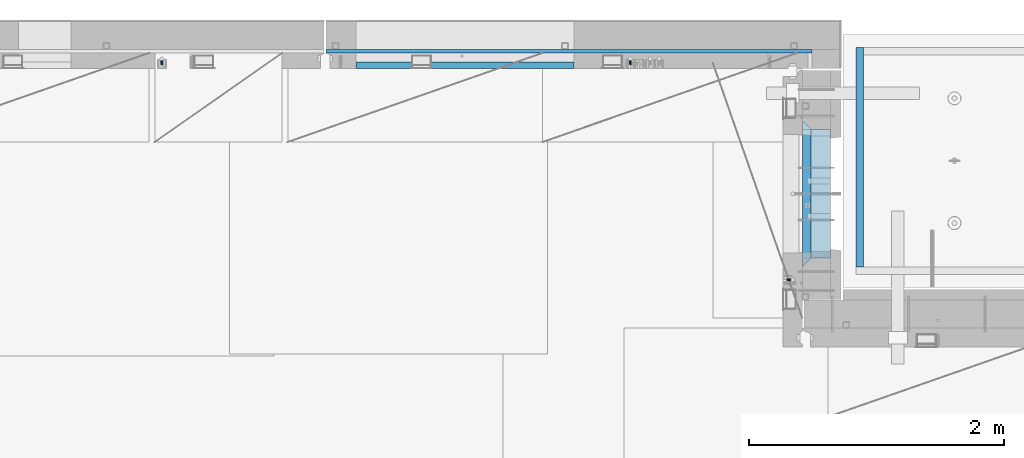
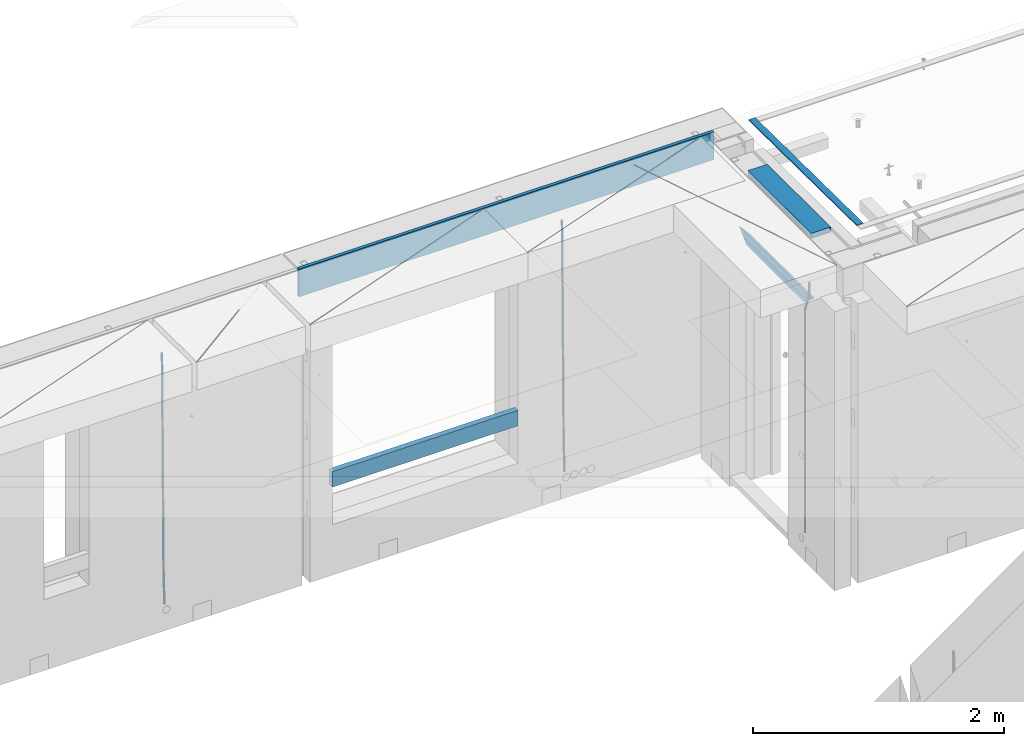
# One storey, part 126 of 352: 9 beams, 4 elements without a shape of their own.
"""IFC2X3 building model written with IfcOpenShell, lengths in millimetres."""

from ifc_helpers import new_model, si_unit, frame, origin_with_axes, place, context, subcontext, project, spatial, faceted_brep, material, type_object, element, aggregate, save


model = new_model("IFC2X3")

# Units and contexts
model_context = context("Model", 3, precision=1e-05, world=origin_with_axes())
body_context = subcontext(model_context, "Body", "Model", "MODEL_VIEW")
ifc_project = project(units=[si_unit("LENGTHUNIT", "METRE", prefix="MILLI"), si_unit("AREAUNIT", "SQUARE_METRE"), si_unit("VOLUMEUNIT", "CUBIC_METRE"), si_unit("MASSUNIT", "GRAM", prefix="KILO"), si_unit("TIMEUNIT", "SECOND"), si_unit("PLANEANGLEUNIT", "RADIAN"), si_unit("SOLIDANGLEUNIT", "STERADIAN"), si_unit("THERMODYNAMICTEMPERATUREUNIT", "DEGREE_CELSIUS"), si_unit("LUMINOUSINTENSITYUNIT", "LUMEN")], contexts=[model_context])

# Site, building, storey
site_placement = place(None, origin_with_axes())
site = spatial("IfcSite", under=ifc_project, at=site_placement, CompositionType="ELEMENT")
building_placement = place(site_placement, origin_with_axes())
building = spatial("IfcBuilding", under=site, at=building_placement, CompositionType="ELEMENT")
storey_placement = place(building_placement, origin_with_axes())
storey = spatial("IfcBuildingStorey", under=building, at=storey_placement, Name="6", CompositionType="ELEMENT", Elevation=0.0)

# Assembly, beams
assembly_1_placement = place(storey_placement, origin_with_axes())
assembly_1 = element("IfcElementAssembly", 1, at=assembly_1_placement, inside=storey, AssemblyPlace="NOTDEFINED", PredefinedType="REINFORCEMENT_UNIT")
ifc_material_1 = material(Name="CONCRETE/C25/30")
beam_type_1 = type_object("IfcBeamType", PredefinedType="NOTDEFINED")
beam_1_placement = place(assembly_1_placement, frame((31494.9951872276, 21060.0002716511, 99140.0), z_axis=(0.0, 0.0, -1.0), x_axis=(0.0, 1.0, 0.0)))
beam_1 = element("IfcBeam", 2, at=beam_1_placement, type_object=beam_type_1, material=ifc_material_1, Name="SK", context=body_context, shape_type="Brep", body=[
    faceted_brep([(70.0000000000164, -35.0, 35.0), (70.0000000000164, 35.0, 35.0), (0.0, -35.0, -35.0), (1079.99961853027, 35.0, 35.0), (1149.99961853027, -35.0, -35.0), (1079.99961853027, -35.0, 35.0)], [[[0, 1, 2]], [[2, 1, 3, 4]], [[0, 2, 4, 5]], [[1, 0, 5, 3]], [[4, 3, 5]]]),
])
beam_type_2 = type_object("IfcBeamType", PredefinedType="NOTDEFINED")
beam_2_placement = place(assembly_1_placement, frame((31494.9951872276, 21130.0002716511, 99080.0), z_axis=(0.0, 0.0, -1.0), x_axis=(0.0, 1.0, 0.0)))
beam_2 = element("IfcBeam", 3, at=beam_2_placement, type_object=beam_type_2, material=ifc_material_1, Name="SK", context=body_context, shape_type="Brep", body=[
    faceted_brep([(0.0, -35.0, -25.0), (43.8457723764295, -35.0, 18.8461538461561), (45.6406441713007, 35.0, 20.6410256410309), (0.0, 35.0, -25.0), (1009.99961853027, 35.0, -25.0), (1009.99961853027, -35.0, -25.0), (966.153464684117, -35.0, 18.8461538461561), (964.358592889246, 35.0, 20.6410256410309)], [[[0, 1, 2, 3]], [[0, 3, 4, 5]], [[1, 0, 5, 6]], [[6, 7, 2, 1]], [[3, 2, 7, 4]], [[6, 5, 4, 7]]]),
])

# Assembly, beam
assembly_2_placement = place(storey_placement, origin_with_axes())
assembly_2 = element("IfcElementAssembly", 4, at=assembly_2_placement, inside=storey, AssemblyPlace="NOTDEFINED", PredefinedType="REINFORCEMENT_UNIT")
ifc_material_2 = material()
beam_type_3 = type_object("IfcBeamType", Name="D20", PredefinedType="NOTDEFINED")
beam_3_placement = place(assembly_2_placement, frame((30110.0000000039, 22654.9999977209, 96990.0), z_axis=(-0.000205762999925498, 0.999642804629538, -0.0267249099901004), x_axis=(4.30000201928125e-08, 0.0267249099948059, 0.999642825806181)))
beam_3 = element("IfcBeam", 5, at=beam_3_placement, type_object=beam_type_3, material=ifc_material_2, Name="JM20", ObjectType="D20", context=body_context, shape_type="Brep", body=[
    faceted_brep([(0.0, -10.0, 0.0), (-4.19531716033816e-08, -7.07106781186667, -7.07106781187031), (60.4266690400545, -7.0710677960451, -7.07106780570757), (60.4266690441291, -9.99999998418934, 6.15546014159918e-09), (0.0, 0.0, -10.0), (60.426669036824, 1.58106558956206e-08, -9.99999999384454), (4.196772351861e-08, 7.07106781186303, -7.07106781186667), (60.4266690363438, 7.07106782768096, -7.07106780570757), (0.0, 10.0, 0.0), (60.4266690388904, 10.0000000158179, 6.15182216279209e-09), (4.196772351861e-08, 7.07106781185939, 7.07106781185939), (60.4266690429649, 7.07106782768096, 7.07106781802577), (0.0, 0.0, 10.0), (60.4266690461809, 1.58179318532348e-08, 10.0000000061555), (-4.19531716033816e-08, -7.07106781187031, 7.07106781185939), (60.4266690466611, -7.07106779605238, 7.07106781802213), (61.0378400410118, -7.07106779588503, -7.07106780564936), (60.991799419251, -9.99999998403655, 6.21366780251265e-09), (61.0569027789461, 1.5985278878361e-08, -9.99999999378269), (61.0378209396877, 7.07106782784831, -7.07106780564936), (60.9917724058905, 10.0000000159635, 6.21366780251265e-09), (60.9457317841297, 7.07106782781193, 7.0710678180767), (60.9266690461809, 1.59488990902901e-08, 10.0000000062028), (60.9457508854539, -7.07106779591413, 7.0710678180767), (61.6489592143771, -7.07106614513759, -7.06310863441468), (61.5568818710308, -9.9999984576425, 0.00735959856683621), (61.6870830769039, 1.71821739058942e-06, -9.99179257185824), (61.6489210170112, 7.07106947854481, -7.06310888312146), (61.556827851804, 10.0000015422847, 0.00735924683976918), (61.4647505084577, 7.07106922979438, 7.07782747982128), (61.4266266459163, 1.36643211590126e-06, 10.0065114172685), (61.464788705809, -7.07106639389531, 7.07782772852806), (176.543135720174, -7.07075579406956, -5.56673531796696), (176.451058376813, -9.99968810657447, 1.50373291501455), (176.581259582701, 0.000312069292704109, -8.49541925541052), (176.543097522794, 7.07137982961285, -5.56673556667374), (176.451004357587, 10.00031189336, 1.50373256329476), (176.35892701424, 7.07137958085514, 8.57420079627263), (176.320803151699, 0.000311717507429421, 11.5028847337162), (176.358965211621, -7.07075604281999, 8.57420104497578), (177.098753836006, -7.07075429323595, -5.55949898843028), (176.98362511232, -9.99968666800123, 1.510669025065), (177.146421932586, 0.000313595905026887, -8.48805862247536), (177.098706077581, 7.07138133041735, -5.55949936166144), (176.983557571715, 10.0003133318824, 1.51066849724157), (176.868428848029, 7.07138095712435, 8.58083651073321), (176.820760751449, 0.000313067976094317, 11.5093961447819), (176.868476606425, -7.07075466652896, 8.58083688396073), (177.654312950661, -7.07075204110879, -5.54863964998367), (177.516135294456, -9.99968450931192, 1.52107783331303), (177.711524267797, 0.000315886711177882, -8.47701274570863), (177.654255632195, 7.07138358250813, -5.54864021007961), (177.516054233929, 10.0003154905207, 1.5210770412159), (177.377876577739, 7.0713830223176, 8.59079452451624), (177.320665260588, 0.000315094497636892, 11.5191676202448), (177.377933896176, -7.07075260129932, 8.59079508461218), (299.436796249574, -7.07025836271714, -3.1681962331204), (299.298618593355, -9.99919083092027, 3.90152125031091), (299.494007566798, 0.000809565110102994, -6.09656932889993), (299.436738931283, 7.07187726089978, -3.16819679320906), (299.298537533061, 10.0008091689197, 3.90152045822106), (299.160359876842, 7.07187670072017, 10.9712379416487), (299.103148559603, 0.000808772889286047, 13.8996110374392), (299.160417195119, -7.07025892290039, 10.9712385017483), (299.98743051647, -7.07025613056248, -3.15743315966392), (299.971788958996, -9.99918809853989, 3.91467979818117), (299.993912075952, 0.000811591617093654, -6.08679785393178), (299.987423933868, 7.07187949325817, -3.1574327280432), (299.971753863239, 10.0008119014747, 3.91467990454839), (299.95611230444, 7.07187992653053, 10.9867922621015), (299.949630744944, 0.000812204350950196, 13.9161569563694), (299.956118887014, -7.07025569729012, 10.9867918304735), (300.538107039494, -7.07025785017686, -3.16575821840888), (300.644985195438, -9.99919020432935, 3.90450175465594), (300.493854948218, 0.000810030429420294, -6.09435592770024), (300.538151196495, 7.071877773491, -3.16575855385963), (300.645047642858, 10.0008097955724, 3.90450128024895), (300.751925798773, 7.07187744142357, 10.9747612533101), (300.796177890064, 0.000809560813650023, 13.9033589625978), (300.751881641787, -7.07025818224065, 10.9747615887682), (2293.36490490142, -7.07648090940347, -33.2930642912361), (2293.47178305736, -10.0054132635523, -26.2228043181785), (2293.32065281013, -0.00541302880083094, -36.2216620005347), (2293.36494905842, 7.06565471425711, -33.2930646266868), (2293.47184550477, 9.99458673634581, -26.2228047925819), (2293.57872366071, 7.06565438219332, -19.1525448195243), (2293.62297575199, -0.00541349841296324, -16.2239471102366), (2293.57867950371, -7.0764812414709, -19.1525444840736), (2294.0658245362, -7.07648309818615, -33.3036607065333), (2294.05312277409, -10.0054150789219, -26.2315929392535), (2294.10928714235, -0.00541549149056664, -36.2335844756526), (2294.15805078732, 7.06565223761572, -33.3050546393533), (2294.18355038921, 9.99458451388637, -26.2335642579346), (2294.17084862708, 7.06565253314329, -19.1614964906439), (2294.12738602093, -0.00541507354500936, -16.2315727215355), (2294.07862237596, -7.07648280265857, -19.1601025578348), (2294.76670261032, -7.08562269121467, -33.294332712383), (2294.63442802057, -10.0129954178956, -26.2238563411993), (2294.89787471293, -0.0156988342423574, -36.2230891548279), (2294.95110548967, 7.05531064255774, -33.2944998654275), (2294.89521307347, 9.98530428734011, -26.2240927312887), (2294.76293848372, 7.0579315606592, -19.1536163601049), (2294.63176638114, -0.0119922963167483, -16.2248599176673), (2294.57853560438, -7.08300177311321, -19.1534492070678), (2316.52657204497, -7.36937582653991, -33.0047303660212), (2316.39429745522, -10.2967485532172, -25.9342539948302), (2316.65774414754, -0.299451969567599, -35.9334868084661), (2316.7109749243, 6.7715575072325, -33.0048975190657), (2316.65508250811, 9.70155115201487, -25.9344903849269), (2316.52280791836, 6.7741784253376, -18.8640140137468), (2316.39163581574, -0.295745431634714, -15.9352575713092), (2316.33840503903, -7.36675490843481, -18.863846860706), (2317.16202064224, -7.37766220584308, -32.9962731735213), (2317.05438744847, -10.3053562613532, -25.9254688497131), (2317.23607125619, -0.306993473008333, -35.925789846493), (2317.23316144495, 6.76474808850253, -32.9979477328052), (2317.15499573652, 9.6950321815566, -25.9278370341635), (2317.04736254275, 6.7673381260538, -18.8570327103698), (2316.97331192881, -0.303330606784584, -15.9275160373909), (2316.97622174003, -7.37507216829545, -18.8553581510787), (2317.79752306276, -7.37578610372293, -32.9880110666527), (2317.71453320107, -10.3033876998124, -25.9168792378296), (2317.81444760226, -0.305295583297266, -35.918287695793), (2317.75539265381, 6.76628640723357, -32.9911928173897), (2317.65495180529, 9.69652304524061, -25.9213789128698), (2317.5719619436, 6.76892144914746, -18.8502470840467), (2317.55503740412, -0.301569071270933, -15.9199704549137), (2317.61409235255, -7.3731510618054, -18.847065333317), (2417.8183084176, -7.07752398473531, -31.6906369377139), (2417.73531855589, -10.0051255808248, -24.6195051088798), (2417.83523295709, -0.007033464313281, -34.6209135668432), (2417.77617800863, 7.06454852621755, -31.6938186884508), (2417.67573716014, 9.99478516423187, -24.6240047839383), (2417.59274729842, 7.06718356813872, -17.5528729551006), (2417.57582275895, -0.00330695228694822, -14.6225963259749), (2417.6348777074, -7.07488894281778, -17.5496912043673)], [[[0, 1, 2, 3]], [[1, 4, 5, 2]], [[4, 6, 7, 5]], [[6, 8, 9, 7]], [[8, 10, 11, 9]], [[10, 12, 13, 11]], [[12, 14, 15, 13]], [[14, 0, 3, 15]], [[14, 12, 10, 8, 6, 4, 1, 0]], [[3, 2, 16, 17]], [[2, 5, 18, 16]], [[5, 7, 19, 18]], [[7, 9, 20, 19]], [[9, 11, 21, 20]], [[11, 13, 22, 21]], [[13, 15, 23, 22]], [[15, 3, 17, 23]], [[17, 16, 24, 25]], [[16, 18, 26, 24]], [[18, 19, 27, 26]], [[19, 20, 28, 27]], [[20, 21, 29, 28]], [[21, 22, 30, 29]], [[22, 23, 31, 30]], [[23, 17, 25, 31]], [[25, 24, 32, 33]], [[24, 26, 34, 32]], [[26, 27, 35, 34]], [[27, 28, 36, 35]], [[28, 29, 37, 36]], [[29, 30, 38, 37]], [[30, 31, 39, 38]], [[31, 25, 33, 39]], [[33, 32, 40, 41]], [[32, 34, 42, 40]], [[34, 35, 43, 42]], [[35, 36, 44, 43]], [[36, 37, 45, 44]], [[37, 38, 46, 45]], [[38, 39, 47, 46]], [[39, 33, 41, 47]], [[41, 40, 48, 49]], [[40, 42, 50, 48]], [[42, 43, 51, 50]], [[43, 44, 52, 51]], [[44, 45, 53, 52]], [[45, 46, 54, 53]], [[46, 47, 55, 54]], [[47, 41, 49, 55]], [[49, 48, 56, 57]], [[48, 50, 58, 56]], [[50, 51, 59, 58]], [[51, 52, 60, 59]], [[52, 53, 61, 60]], [[53, 54, 62, 61]], [[54, 55, 63, 62]], [[55, 49, 57, 63]], [[57, 56, 64, 65]], [[56, 58, 66, 64]], [[58, 59, 67, 66]], [[59, 60, 68, 67]], [[60, 61, 69, 68]], [[61, 62, 70, 69]], [[62, 63, 71, 70]], [[63, 57, 65, 71]], [[65, 64, 72, 73]], [[64, 66, 74, 72]], [[66, 67, 75, 74]], [[67, 68, 76, 75]], [[68, 69, 77, 76]], [[69, 70, 78, 77]], [[70, 71, 79, 78]], [[71, 65, 73, 79]], [[73, 72, 80, 81]], [[72, 74, 82, 80]], [[74, 75, 83, 82]], [[75, 76, 84, 83]], [[76, 77, 85, 84]], [[77, 78, 86, 85]], [[78, 79, 87, 86]], [[79, 73, 81, 87]], [[81, 80, 88, 89]], [[80, 82, 90, 88]], [[82, 83, 91, 90]], [[83, 84, 92, 91]], [[84, 85, 93, 92]], [[85, 86, 94, 93]], [[86, 87, 95, 94]], [[87, 81, 89, 95]], [[89, 88, 96, 97]], [[88, 90, 98, 96]], [[90, 91, 99, 98]], [[91, 92, 100, 99]], [[92, 93, 101, 100]], [[93, 94, 102, 101]], [[94, 95, 103, 102]], [[95, 89, 97, 103]], [[97, 96, 104, 105]], [[96, 98, 106, 104]], [[98, 99, 107, 106]], [[99, 100, 108, 107]], [[100, 101, 109, 108]], [[101, 102, 110, 109]], [[102, 103, 111, 110]], [[103, 97, 105, 111]], [[105, 104, 112, 113]], [[104, 106, 114, 112]], [[106, 107, 115, 114]], [[107, 108, 116, 115]], [[108, 109, 117, 116]], [[109, 110, 118, 117]], [[110, 111, 119, 118]], [[111, 105, 113, 119]], [[113, 112, 120, 121]], [[112, 114, 122, 120]], [[114, 115, 123, 122]], [[115, 116, 124, 123]], [[116, 117, 125, 124]], [[117, 118, 126, 125]], [[118, 119, 127, 126]], [[119, 113, 121, 127]], [[121, 120, 128, 129]], [[120, 122, 130, 128]], [[122, 123, 131, 130]], [[123, 124, 132, 131]], [[124, 125, 133, 132]], [[125, 126, 134, 133]], [[126, 127, 135, 134]], [[127, 121, 129, 135]], [[130, 131, 132, 133, 134, 135, 129, 128]]]),
])

assembly_3_placement = place(storey_placement, origin_with_axes())
assembly_3 = element("IfcElementAssembly", 6, at=assembly_3_placement, inside=storey, AssemblyPlace="NOTDEFINED", PredefinedType="REINFORCEMENT_UNIT")
beam_4_placement = place(assembly_3_placement, frame((26430.0000000039, 22654.999995444, 96990.0), z_axis=(-0.000205762999925498, 0.999642804629538, -0.0267249099901004), x_axis=(4.30000201928125e-08, 0.0267249099948059, 0.999642825806181)))
beam_4 = element("IfcBeam", 7, at=beam_4_placement, type_object=beam_type_3, material=ifc_material_2, Name="JM20", ObjectType="D20", context=body_context, shape_type="Brep", body=[
    faceted_brep([(0.0, -10.0, 0.0), (-4.19531716033816e-08, -7.07106781186667, -7.07106781187031), (60.4266690400545, -7.0710677960451, -7.07106780570757), (60.4266690441291, -9.99999998418934, 6.15546014159918e-09), (0.0, 0.0, -10.0), (60.426669036824, 1.58106558956206e-08, -9.99999999384454), (4.196772351861e-08, 7.07106781186303, -7.07106781186667), (60.4266690363438, 7.07106782768096, -7.07106780570757), (0.0, 10.0, 0.0), (60.4266690388904, 10.0000000158179, 6.15182216279209e-09), (4.196772351861e-08, 7.07106781185939, 7.07106781185939), (60.4266690429649, 7.07106782768096, 7.07106781802577), (0.0, 0.0, 10.0), (60.4266690461809, 1.58179318532348e-08, 10.0000000061555), (-4.19531716033816e-08, -7.07106781187031, 7.07106781185939), (60.4266690466611, -7.07106779605238, 7.07106781802213), (61.0378400410118, -7.07106779588503, -7.07106780564936), (60.991799419251, -9.99999998403655, 6.21366780251265e-09), (61.0569027789461, 1.5985278878361e-08, -9.99999999378269), (61.0378209396877, 7.07106782784831, -7.07106780564936), (60.9917724058905, 10.0000000159635, 6.21366780251265e-09), (60.9457317841297, 7.07106782781193, 7.0710678180767), (60.9266690461809, 1.59488990902901e-08, 10.0000000062028), (60.9457508854539, -7.07106779591413, 7.0710678180767), (61.6489592143771, -7.07106614513759, -7.06310863441468), (61.5568818710308, -9.9999984576425, 0.00735959856683621), (61.6870830769039, 1.71821739058942e-06, -9.99179257185824), (61.6489210170112, 7.07106947854481, -7.06310888312146), (61.556827851804, 10.0000015422847, 0.00735924683976918), (61.4647505084577, 7.07106922979438, 7.07782747982128), (61.4266266459163, 1.36643211590126e-06, 10.0065114172685), (61.464788705809, -7.07106639389531, 7.07782772852806), (176.543135720174, -7.07075579406956, -5.56673531796696), (176.451058376813, -9.99968810657447, 1.50373291501455), (176.581259582701, 0.000312069292704109, -8.49541925541052), (176.543097522794, 7.07137982961285, -5.56673556667374), (176.451004357587, 10.00031189336, 1.50373256329476), (176.35892701424, 7.07137958085514, 8.57420079627263), (176.320803151699, 0.000311717507429421, 11.5028847337162), (176.358965211621, -7.07075604281999, 8.57420104497578), (177.098753836006, -7.07075429323595, -5.55949898843028), (176.98362511232, -9.99968666800123, 1.510669025065), (177.146421932586, 0.000313595905026887, -8.48805862247536), (177.098706077581, 7.07138133041735, -5.55949936166144), (176.983557571715, 10.0003133318824, 1.51066849724157), (176.868428848029, 7.07138095712435, 8.58083651073321), (176.820760751449, 0.000313067976094317, 11.5093961447819), (176.868476606425, -7.07075466652896, 8.58083688396073), (177.654312950661, -7.07075204110879, -5.54863964998367), (177.516135294456, -9.99968450931192, 1.52107783331303), (177.711524267797, 0.000315886711177882, -8.47701274570863), (177.654255632195, 7.07138358250813, -5.54864021007961), (177.516054233929, 10.0003154905207, 1.5210770412159), (177.377876577739, 7.0713830223176, 8.59079452451624), (177.320665260588, 0.000315094497636892, 11.5191676202448), (177.377933896176, -7.07075260129932, 8.59079508461218), (299.436796249574, -7.07025836271714, -3.1681962331204), (299.298618593355, -9.99919083092027, 3.90152125031091), (299.494007566798, 0.000809565110102994, -6.09656932889993), (299.436738931283, 7.07187726089978, -3.16819679320906), (299.298537533061, 10.0008091689197, 3.90152045822106), (299.160359876842, 7.07187670072017, 10.9712379416487), (299.103148559603, 0.000808772889286047, 13.8996110374392), (299.160417195119, -7.07025892290039, 10.9712385017483), (299.98743051647, -7.07025613056248, -3.15743315966392), (299.971788958996, -9.99918809853989, 3.91467979818117), (299.993912075952, 0.000811591617093654, -6.08679785393178), (299.987423933868, 7.07187949325817, -3.1574327280432), (299.971753863239, 10.0008119014747, 3.91467990454839), (299.95611230444, 7.07187992653053, 10.9867922621015), (299.949630744944, 0.000812204350950196, 13.9161569563694), (299.956118887014, -7.07025569729012, 10.9867918304735), (300.538107039494, -7.07025785017686, -3.16575821840888), (300.644985195438, -9.99919020432935, 3.90450175465594), (300.493854948218, 0.000810030429420294, -6.09435592770024), (300.538151196495, 7.071877773491, -3.16575855385963), (300.645047642858, 10.0008097955724, 3.90450128024895), (300.751925798773, 7.07187744142357, 10.9747612533101), (300.796177890064, 0.000809560813650023, 13.9033589625978), (300.751881641787, -7.07025818224065, 10.9747615887682), (2293.36490490142, -7.07648090940347, -33.2930642912361), (2293.47178305736, -10.0054132635523, -26.2228043181785), (2293.32065281013, -0.00541302880083094, -36.2216620005347), (2293.36494905842, 7.06565471425711, -33.2930646266868), (2293.47184550477, 9.99458673634581, -26.2228047925819), (2293.57872366071, 7.06565438219332, -19.1525448195243), (2293.62297575199, -0.00541349841296324, -16.2239471102366), (2293.57867950371, -7.0764812414709, -19.1525444840736), (2294.0658245362, -7.07648309818615, -33.3036607065333), (2294.05312277409, -10.0054150789219, -26.2315929392535), (2294.10928714235, -0.00541549149056664, -36.2335844756526), (2294.15805078732, 7.06565223761572, -33.3050546393533), (2294.18355038921, 9.99458451388637, -26.2335642579346), (2294.17084862708, 7.06565253314329, -19.1614964906439), (2294.12738602093, -0.00541507354500936, -16.2315727215355), (2294.07862237596, -7.07648280265857, -19.1601025578348), (2294.76670261032, -7.08562269121467, -33.294332712383), (2294.63442802057, -10.0129954178956, -26.2238563411993), (2294.89787471293, -0.0156988342423574, -36.2230891548279), (2294.95110548967, 7.05531064255774, -33.2944998654275), (2294.89521307347, 9.98530428734011, -26.2240927312887), (2294.76293848372, 7.0579315606592, -19.1536163601049), (2294.63176638114, -0.0119922963167483, -16.2248599176673), (2294.57853560438, -7.08300177311321, -19.1534492070678), (2316.52657204497, -7.36937582653991, -33.0047303660212), (2316.39429745522, -10.2967485532172, -25.9342539948302), (2316.65774414754, -0.299451969567599, -35.9334868084661), (2316.7109749243, 6.7715575072325, -33.0048975190657), (2316.65508250811, 9.70155115201487, -25.9344903849269), (2316.52280791836, 6.7741784253376, -18.8640140137468), (2316.39163581574, -0.295745431634714, -15.9352575713092), (2316.33840503903, -7.36675490843481, -18.863846860706), (2317.16202064224, -7.37766220584308, -32.9962731735213), (2317.05438744847, -10.3053562613532, -25.9254688497131), (2317.23607125619, -0.306993473008333, -35.925789846493), (2317.23316144495, 6.76474808850253, -32.9979477328052), (2317.15499573652, 9.6950321815566, -25.9278370341635), (2317.04736254275, 6.7673381260538, -18.8570327103698), (2316.97331192881, -0.303330606784584, -15.9275160373909), (2316.97622174003, -7.37507216829545, -18.8553581510787), (2317.79752306276, -7.37578610372293, -32.9880110666527), (2317.71453320107, -10.3033876998124, -25.9168792378296), (2317.81444760226, -0.305295583297266, -35.918287695793), (2317.75539265381, 6.76628640723357, -32.9911928173897), (2317.65495180529, 9.69652304524061, -25.9213789128698), (2317.5719619436, 6.76892144914746, -18.8502470840467), (2317.55503740412, -0.301569071270933, -15.9199704549137), (2317.61409235255, -7.3731510618054, -18.847065333317), (2417.8183084176, -7.07752398473531, -31.6906369377139), (2417.73531855589, -10.0051255808248, -24.6195051088798), (2417.83523295709, -0.007033464313281, -34.6209135668432), (2417.77617800863, 7.06454852621755, -31.6938186884508), (2417.67573716014, 9.99478516423187, -24.6240047839383), (2417.59274729842, 7.06718356813872, -17.5528729551006), (2417.57582275895, -0.00330695228694822, -14.6225963259749), (2417.6348777074, -7.07488894281778, -17.5496912043673)], [[[0, 1, 2, 3]], [[1, 4, 5, 2]], [[4, 6, 7, 5]], [[6, 8, 9, 7]], [[8, 10, 11, 9]], [[10, 12, 13, 11]], [[12, 14, 15, 13]], [[14, 0, 3, 15]], [[14, 12, 10, 8, 6, 4, 1, 0]], [[3, 2, 16, 17]], [[2, 5, 18, 16]], [[5, 7, 19, 18]], [[7, 9, 20, 19]], [[9, 11, 21, 20]], [[11, 13, 22, 21]], [[13, 15, 23, 22]], [[15, 3, 17, 23]], [[17, 16, 24, 25]], [[16, 18, 26, 24]], [[18, 19, 27, 26]], [[19, 20, 28, 27]], [[20, 21, 29, 28]], [[21, 22, 30, 29]], [[22, 23, 31, 30]], [[23, 17, 25, 31]], [[25, 24, 32, 33]], [[24, 26, 34, 32]], [[26, 27, 35, 34]], [[27, 28, 36, 35]], [[28, 29, 37, 36]], [[29, 30, 38, 37]], [[30, 31, 39, 38]], [[31, 25, 33, 39]], [[33, 32, 40, 41]], [[32, 34, 42, 40]], [[34, 35, 43, 42]], [[35, 36, 44, 43]], [[36, 37, 45, 44]], [[37, 38, 46, 45]], [[38, 39, 47, 46]], [[39, 33, 41, 47]], [[41, 40, 48, 49]], [[40, 42, 50, 48]], [[42, 43, 51, 50]], [[43, 44, 52, 51]], [[44, 45, 53, 52]], [[45, 46, 54, 53]], [[46, 47, 55, 54]], [[47, 41, 49, 55]], [[49, 48, 56, 57]], [[48, 50, 58, 56]], [[50, 51, 59, 58]], [[51, 52, 60, 59]], [[52, 53, 61, 60]], [[53, 54, 62, 61]], [[54, 55, 63, 62]], [[55, 49, 57, 63]], [[57, 56, 64, 65]], [[56, 58, 66, 64]], [[58, 59, 67, 66]], [[59, 60, 68, 67]], [[60, 61, 69, 68]], [[61, 62, 70, 69]], [[62, 63, 71, 70]], [[63, 57, 65, 71]], [[65, 64, 72, 73]], [[64, 66, 74, 72]], [[66, 67, 75, 74]], [[67, 68, 76, 75]], [[68, 69, 77, 76]], [[69, 70, 78, 77]], [[70, 71, 79, 78]], [[71, 65, 73, 79]], [[73, 72, 80, 81]], [[72, 74, 82, 80]], [[74, 75, 83, 82]], [[75, 76, 84, 83]], [[76, 77, 85, 84]], [[77, 78, 86, 85]], [[78, 79, 87, 86]], [[79, 73, 81, 87]], [[81, 80, 88, 89]], [[80, 82, 90, 88]], [[82, 83, 91, 90]], [[83, 84, 92, 91]], [[84, 85, 93, 92]], [[85, 86, 94, 93]], [[86, 87, 95, 94]], [[87, 81, 89, 95]], [[89, 88, 96, 97]], [[88, 90, 98, 96]], [[90, 91, 99, 98]], [[91, 92, 100, 99]], [[92, 93, 101, 100]], [[93, 94, 102, 101]], [[94, 95, 103, 102]], [[95, 89, 97, 103]], [[97, 96, 104, 105]], [[96, 98, 106, 104]], [[98, 99, 107, 106]], [[99, 100, 108, 107]], [[100, 101, 109, 108]], [[101, 102, 110, 109]], [[102, 103, 111, 110]], [[103, 97, 105, 111]], [[105, 104, 112, 113]], [[104, 106, 114, 112]], [[106, 107, 115, 114]], [[107, 108, 116, 115]], [[108, 109, 117, 116]], [[109, 110, 118, 117]], [[110, 111, 119, 118]], [[111, 105, 113, 119]], [[113, 112, 120, 121]], [[112, 114, 122, 120]], [[114, 115, 123, 122]], [[115, 116, 124, 123]], [[116, 117, 125, 124]], [[117, 118, 126, 125]], [[118, 119, 127, 126]], [[119, 113, 121, 127]], [[121, 120, 128, 129]], [[120, 122, 130, 128]], [[122, 123, 131, 130]], [[123, 124, 132, 131]], [[124, 125, 133, 132]], [[125, 126, 134, 133]], [[126, 127, 135, 134]], [[127, 121, 129, 135]], [[130, 131, 132, 133, 134, 135, 129, 128]]]),
])
aggregate(assembly_3, [beam_4])

# Beam
beam_5_placement = place(assembly_1_placement, frame((31384.9951872298, 20959.9999999916, 99407.5), z_axis=(-0.999999913638316, 0.000415599999849952, 0.0), x_axis=(0.0, 0.0, -1.0)))
beam_5 = element("IfcBeam", 8, at=beam_5_placement, type_object=beam_type_3, material=ifc_material_2, Name="JM20", ObjectType="D20", context=body_context, shape_type="Brep", body=[
    faceted_brep([(0.0, -10.0, 0.0), (-4.19531716033816e-08, -7.07106781186667, -7.07106781187031), (113.248091332178, -7.0710684840451, -7.0710678117357), (113.248091314759, -10.0000006713562, -2.51020537689328e-10), (0.0, 0.0, -10.0), (113.248091374131, -6.72178430249915e-07, -9.99999999986903), (4.196772351861e-08, 7.07106781186303, -7.07106781186667), (113.248091416113, 7.07106713968824, -7.07106781173934), (0.0, 10.0, 0.0), (113.248091433488, 9.99999932782521, 1.30967237055302e-10), (4.196772351861e-08, 7.07106781185939, 7.07106781185939), (113.248091416113, 7.0710671396846, 7.071067811994), (0.0, 0.0, 10.0), (113.248091374131, -6.72174792271107e-07, 10.0000000001273), (-4.19531716033816e-08, -7.07106781187031, 7.07106781185939), (113.248091332178, -7.0710684840451, 7.071067811994), (130.699843527167, -7.06993249763036, -4.33745683788584), (128.538066582521, -9.99900540317321, 2.39499413731755), (131.594536475241, 0.00119355250353692, -7.12624594330919), (130.698046432328, 7.07220300913468, -4.33773834422391), (128.535525107087, 10.0009944322555, 2.39459602660281), (126.373748162892, 7.07192152754578, 9.1270470011732), (125.479055214906, 0.000795477419160306, 11.9158361066184), (126.37554525779, -7.07021397921199, 9.12732850753673), (240.336258550378, -7.05529970173666, 30.8729495437874), (238.174481606227, -9.98437260450009, 37.6054005176375), (241.230951498423, 0.0158263482953771, 28.0841604381058), (240.334461455612, 7.0868358050102, 30.8726680369582), (238.171940130502, 10.0156272283348, 37.6050024077231), (236.010163186409, 7.08655432384694, 44.3374533824244), (235.115470238379, 0.0154282738185429, 47.1262424881097), (236.011960281176, -7.05558118289991, 44.3377348892536), (253.461915329972, -7.05444528127919, 32.9289287376414), (253.46191532613, -9.98337746617108, 39.9999965521893), (253.461915339081, 0.0166225284556276, 29.9999965443676), (253.461915348205, 7.08769034247234, 32.9289287273205), (253.461915352003, 10.0166225357716, 39.9999965370152), (253.461915348293, 7.08769035281148, 47.0710643509774), (253.461915339183, 0.0166225430875784, 49.999996544273), (253.46191533003, -7.05444527093641, 47.0710643613093), (2417.50000002384, -7.0544364694706, 32.9289287374122), (2417.5000000337, -9.98336865393321, 39.9999965507959), (2417.49999999997, 0.0166313408753922, 29.9999965456082), (2417.49999997609, 7.08769915426274, 32.9289287300708), (2417.4999999662, 10.0166313460668, 39.9999965404204), (2417.49999997608, 7.08769916160054, 47.0710643538114), (2417.49999999994, 0.0166313512581837, 49.9999965456154), (2417.50000002382, -7.05443646212916, 47.0710643611455)], [[[0, 1, 2, 3]], [[1, 4, 5, 2]], [[4, 6, 7, 5]], [[6, 8, 9, 7]], [[8, 10, 11, 9]], [[10, 12, 13, 11]], [[12, 14, 15, 13]], [[14, 0, 3, 15]], [[14, 12, 10, 8, 6, 4, 1, 0]], [[3, 2, 16, 17]], [[2, 5, 18, 16]], [[5, 7, 19, 18]], [[7, 9, 20, 19]], [[9, 11, 21, 20]], [[11, 13, 22, 21]], [[13, 15, 23, 22]], [[15, 3, 17, 23]], [[17, 16, 24, 25]], [[16, 18, 26, 24]], [[18, 19, 27, 26]], [[19, 20, 28, 27]], [[20, 21, 29, 28]], [[21, 22, 30, 29]], [[22, 23, 31, 30]], [[23, 17, 25, 31]], [[25, 24, 32, 33]], [[24, 26, 34, 32]], [[26, 27, 35, 34]], [[27, 28, 36, 35]], [[28, 29, 37, 36]], [[29, 30, 38, 37]], [[30, 31, 39, 38]], [[31, 25, 33, 39]], [[33, 32, 40, 41]], [[32, 34, 42, 40]], [[34, 35, 43, 42]], [[35, 36, 44, 43]], [[36, 37, 45, 44]], [[37, 38, 46, 45]], [[38, 39, 47, 46]], [[39, 33, 41, 47]], [[42, 43, 44, 45, 46, 47, 41, 40]]]),
])

ifc_material_3 = material(Name="TIMBER/T24")
beam_type_4 = type_object("IfcBeamType", PredefinedType="NOTDEFINED")
beam_6_placement = place(assembly_2_placement, frame((29665.0002980493, 22644.9998418812, 97685.0), z_axis=(0.0, 0.0, 1.0), x_axis=(-1.0, 3.00000001838171e-08, 0.0)))
beam_6 = element("IfcBeam", 9, at=beam_6_placement, type_object=beam_type_4, material=ifc_material_3, context=body_context, shape_type="Brep", body=[
    faceted_brep([(-3.63797880709171e-12, 24.9999999999964, -75.0), (-3.63797880709171e-12, 24.9999999999964, 75.0), (1710.0, 25.0, 75.0), (1710.0, 25.0, -75.0), (0.0, -25.0000000000073, 75.0), (1709.99999999999, -25.0, 75.0), (0.0, -25.0000000000073, -75.0), (1709.99999999999, -25.0, -75.0)], [[[0, 1, 2, 3]], [[1, 4, 5, 2]], [[4, 6, 7, 5]], [[6, 0, 3, 7]], [[5, 7, 3, 2]], [[6, 4, 1, 0]]]),
])

# Assembly, beam
assembly_4_placement = place(storey_placement, origin_with_axes())
assembly_4 = element("IfcElementAssembly", 10, at=assembly_4_placement, inside=storey, AssemblyPlace="NOTDEFINED", PredefinedType="REINFORCEMENT_UNIT")
ifc_material_4 = material(Name="CONCRETE/Concrete_Undefined")
beam_type_5 = type_object("IfcBeamType", PredefinedType="NOTDEFINED")
beam_7_placement = place(assembly_4_placement, frame((31909.9986098709, 21060.0524822207, 99725.2791116282), z_axis=(7.99999906921644e-09, 0.0107912409985276, 0.999941772863656), x_axis=(7.22999999800065e-07, 0.999941772863395, -0.0107912409985247)))
beam_7 = element("IfcBeam", 11, at=beam_7_placement, type_object=beam_type_5, material=ifc_material_4, context=body_context, shape_type="Brep", body=[
    faceted_brep([(2.5465851649642e-11, 29.9999999999982, -4.99999999998545), (-2.91038304567337e-11, 29.9999999999982, 5.0), (1725.04446838825, 29.9999999999927, 4.99999999998545), (1725.04446838825, 29.9999999999927, -5.00000000001455), (-2.5465851649642e-11, -30.0000000000018, 5.0), (1725.04446838824, -30.0000000000073, 4.99999999998545), (2.72848410531878e-11, -30.0000000000018, -4.99999999998545), (1725.04446838824, -30.0000000000073, -5.0)], [[[0, 1, 2, 3]], [[1, 4, 5, 2]], [[4, 6, 7, 5]], [[6, 0, 3, 7]], [[5, 7, 3, 2]], [[6, 4, 1, 0]]]),
])
aggregate(assembly_4, [beam_7])

# Beam
beam_type_6 = type_object("IfcBeamType", Name="270X30", PredefinedType="NOTDEFINED")
beam_8_placement = place(assembly_2_placement, frame((31535.0, 22755.0, 99605.0), z_axis=(0.0, 0.0, 1.0), x_axis=(-1.0, 3.00000001838171e-08, 0.0)))
beam_8 = element("IfcBeam", 12, at=beam_8_placement, type_object=beam_type_6, material=ifc_material_1, ObjectType="270X30", context=body_context, shape_type="Brep", body=[
    faceted_brep([(0.0, 15.0, -135.0), (0.0, 15.0, 135.0), (3815.00000000003, 15.0, 135.0), (3815.00000000003, 15.0, -135.0), (0.0, -15.0, 135.0), (3815.00000000003, -15.0, 135.0), (0.0, -15.0, -135.0), (3815.00000000003, -15.0, -135.0)], [[[0, 1, 2, 3]], [[1, 4, 5, 2]], [[4, 6, 7, 5]], [[6, 0, 3, 7]], [[5, 7, 3, 2]], [[6, 4, 1, 0]]]),
])

aggregate(assembly_2, [beam_3, beam_8, beam_6])

ifc_material_5 = material(Name="TIMBER")
beam_type_7 = type_object("IfcBeamType", PredefinedType="NOTDEFINED")
beam_9_placement = place(assembly_1_placement, frame((31589.9951872276, 22140.0000381475, 99715.0), z_axis=(0.0, 0.0, 1.0), x_axis=(0.0, -1.0, 0.0)))
beam_9 = element("IfcBeam", 13, at=beam_9_placement, type_object=beam_type_7, material=ifc_material_5, context=body_context, shape_type="Brep", body=[
    faceted_brep([(0.0, 90.0, -25.0), (0.0, 90.0, 25.0), (1009.99983857082, 90.0, 25.0), (1009.99983857082, 90.0, -25.0), (0.0, -90.0, 25.0), (1009.99983857082, -90.0, 25.0), (0.0, -90.0, -25.0), (1009.99983857082, -90.0, -25.0)], [[[0, 1, 2, 3]], [[1, 4, 5, 2]], [[4, 6, 7, 5]], [[6, 0, 3, 7]], [[5, 7, 3, 2]], [[6, 4, 1, 0]]]),
])

aggregate(assembly_1, [beam_5, beam_9, beam_1, beam_2])

save(model, "model.ifc")
